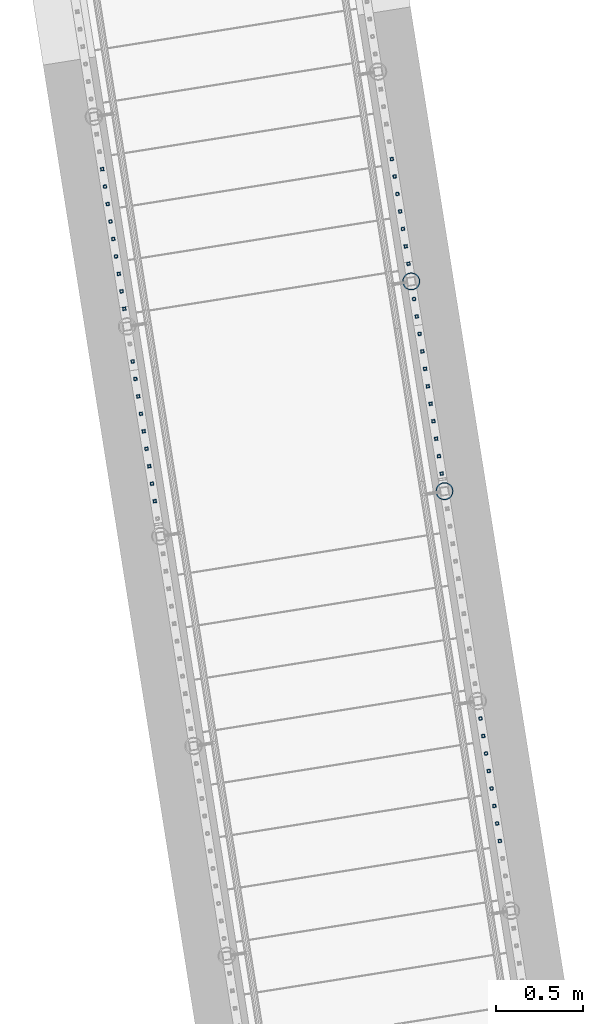
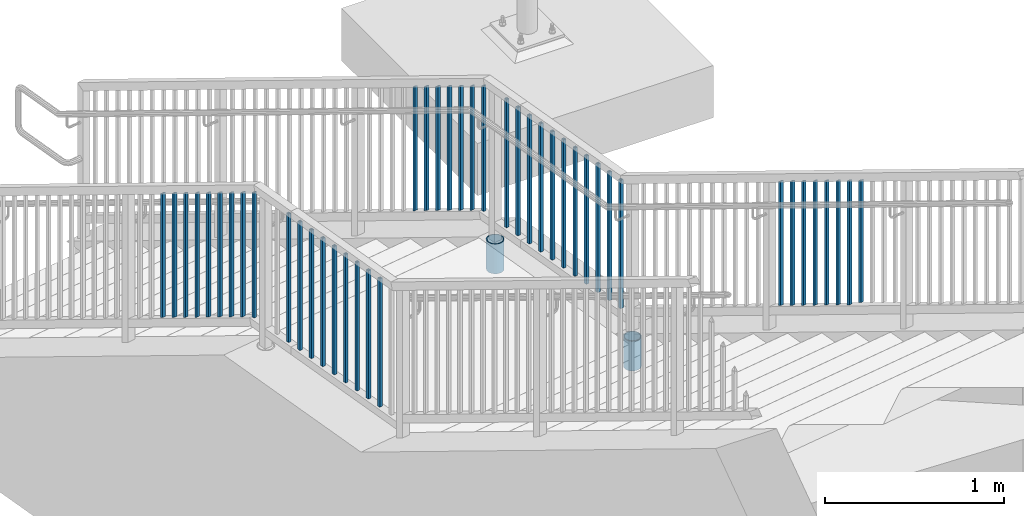
# One storey, part 226 of 975: 46 columns.
"""IFC2X3 building model written with IfcOpenShell, lengths in millimetres."""

from ifc_helpers import new_model, si_unit, frame, origin_with_axes, place, context, subcontext, project, spatial, faceted_brep, material, type_object, element, save


model = new_model("IFC2X3")

# Units and contexts
model_context = context("Model", 3, precision=1e-05, world=origin_with_axes())
body_context = subcontext(model_context, "Body", "Model", "MODEL_VIEW")
ifc_project = project(units=[si_unit("LENGTHUNIT", "METRE", prefix="MILLI"), si_unit("AREAUNIT", "SQUARE_METRE"), si_unit("VOLUMEUNIT", "CUBIC_METRE"), si_unit("MASSUNIT", "GRAM", prefix="KILO"), si_unit("TIMEUNIT", "SECOND"), si_unit("PLANEANGLEUNIT", "RADIAN"), si_unit("SOLIDANGLEUNIT", "STERADIAN"), si_unit("THERMODYNAMICTEMPERATUREUNIT", "DEGREE_CELSIUS"), si_unit("LUMINOUSINTENSITYUNIT", "LUMEN")], contexts=[model_context])

# Site, building, storey
site_placement = place(None, origin_with_axes())
site = spatial("IfcSite", under=ifc_project, at=site_placement, CompositionType="ELEMENT")
building_placement = place(site_placement, origin_with_axes())
building = spatial("IfcBuilding", under=site, at=building_placement, Name="Undefined", CompositionType="ELEMENT")
storey_placement = place(building_placement, origin_with_axes())
storey = spatial("IfcBuildingStorey", under=building, at=storey_placement, Name="Undefined", CompositionType="ELEMENT", Elevation=0.0)

# Columns
ifc_material_1 = material()
column_type_1 = type_object("IfcColumnType", Name="HSS3/4X3/4X.120_TUBES", PredefinedType="NOTDEFINED")
column_1_placement = place(storey_placement, frame((-174.319591391173, 22259.748514681, 3357.53490606116), z_axis=(-0.987688340611262, -0.156434464938429, 0.0), x_axis=(0.0, 0.0, 1.0)))
element("IfcColumn", 1, at=column_1_placement, inside=storey, type_object=column_type_1, material=ifc_material_1, Name="PICKET", ObjectType="HSS3/4X3/4X.120_TUBES", context=body_context, shape_type="Brep", body=[
    faceted_brep([(-3.50571911954194, 6.34999999999491, -6.34999999999809), (3.50573940444565, -6.34999999999491, -6.34999999999991), (838.195107257512, -6.34999999999491, -6.35000000000082), (831.183648729623, 6.34999999999491, -6.34999999999945), (3.50571915819046, -6.34999999998763, 6.34999999999786), (838.195107270213, -6.34999999999127, 6.34999999999809), (-3.50573936579713, 6.34999999999854, 6.34999999999968), (831.183648742323, 6.35000000000218, 6.34999999999945), (-5.25857868897492, 9.5249999999869, -9.52499999999668), (-5.25860905835771, 9.52500000000146, 9.52499999999964), (829.430784113527, 9.52499999999782, 9.52499999999964), (829.430784094476, 9.52499999999054, -9.52499999999827), (5.25857872762344, -9.52499999998327, 9.52499999999645), (839.947971905361, -9.5249999999869, 9.52499999999736), (5.25860909700623, -9.52499999999418, -9.52499999999986), (839.947971886309, -9.52499999999782, -9.525000000001)], [[[0, 1, 2, 3]], [[1, 4, 5, 2]], [[4, 6, 7, 5]], [[6, 0, 3, 7]], [[8, 9, 10, 11]], [[9, 12, 13, 10]], [[12, 14, 15, 13]], [[14, 8, 11, 15]], [[13, 15, 11, 10], [5, 7, 3, 2]], [[14, 12, 9, 8], [6, 4, 1, 0]]]),
])
for number, where, z_axis, x_axis, name in (
    (2, (-190.222182018063, 22360.1535194662, 3301.41200880053), (-0.987688340611262, -0.156434464938429, 0.0), (0.0, 0.0, 1.0), "PICKET"),
    (3, (-206.124772644793, 22460.5585242503, 3245.28911153992), (-0.987688340611262, -0.156434464938429, 0.0), (0.0, 0.0, 1.0), "PICKET"),
    (4, (-222.027363271527, 22560.9635290345, 3189.1662142793), (-0.987688340611262, -0.156434464938429, 0.0), (0.0, 0.0, 1.0), "PICKET"),
    (5, (-237.929953898256, 22661.3685338186, 3133.04331701868), (-0.987688340611262, -0.156434464938429, 0.0), (0.0, 0.0, 1.0), "PICKET"),
    (6, (-253.832544524988, 22761.7735386028, 3076.92041975807), (-0.987688340611262, -0.156434464938429, 0.0), (0.0, 0.0, 1.0), "PICKET"),
    (7, (-269.73513515172, 22862.1785433869, 3020.79752249744), (-0.987688340611262, -0.156434464938429, 0.0), (0.0, 0.0, 1.0), "PICKET"),
    (8, (-285.637725778453, 22962.5835481711, 2964.67462523683), (-0.987688340611262, -0.156434464938429, 0.0), (0.0, 0.0, 1.0), "PICKET"),
):
    element("IfcColumn", number, at=place(storey_placement, frame(where, z_axis=z_axis, x_axis=x_axis)), inside=storey, type_object=column_type_1, material=ifc_material_1, Name=name, ObjectType="HSS3/4X3/4X.120_TUBES", context=body_context, shape_type="Brep", body=[
        faceted_brep([(-17.9916664943412, 6.34999999999491, -6.34999999999945), (-10.9802079664514, -6.34999999999127, -6.35000000000173), (838.195107257512, -6.34999999999491, -6.35000000000082), (831.183648729623, 6.34999999999491, -6.34999999999945), (-10.9802079664505, -6.34999999998763, 6.34999999999764), (838.195107270213, -6.34999999999127, 6.34999999999809), (-17.9916664943403, 6.35000000000218, 6.34999999999945), (831.183648742323, 6.35000000000218, 6.34999999999945), (-19.7445311263136, 9.52499999999054, -9.52499999999918), (-19.7445311263118, 9.52500000000146, 9.52499999999918), (829.430784113527, 9.52499999999782, 9.52499999999964), (829.430784094476, 9.52499999999054, -9.52499999999827), (-9.22734333447806, -9.52499999998327, 9.52499999999691), (839.947971905361, -9.5249999999869, 9.52499999999736), (-9.22734333447897, -9.52499999999418, -9.525000000001), (839.947971886309, -9.52499999999782, -9.525000000001)], [[[0, 1, 2, 3]], [[1, 4, 5, 2]], [[4, 6, 7, 5]], [[6, 0, 3, 7]], [[8, 9, 10, 11]], [[9, 12, 13, 10]], [[12, 14, 15, 13]], [[14, 8, 11, 15]], [[13, 15, 11, 10], [5, 7, 3, 2]], [[14, 12, 9, 8], [6, 4, 1, 0]]]),
    ])
for number, where, z_axis, x_axis, name in (
    (9, (-666.980695255974, 25370.2873334289, 2158.99369648662), (-0.987688340611262, -0.156434464938429, 0.0), (0.0, 0.0, 1.0), "PICKET"),
    (10, (-651.108765229682, 25270.0759091957, 2158.99433328347), (-0.987688340611262, -0.156434464938429, 0.0), (0.0, 0.0, 1.0), "PICKET"),
    (11, (-635.236835203391, 25169.8644849625, 2158.99497008033), (-0.987688340611262, -0.156434464938429, 0.0), (0.0, 0.0, 1.0), "PICKET"),
    (12, (-619.364905177102, 25069.6530607292, 2158.99560687718), (-0.987688340611262, -0.156434464938429, 0.0), (0.0, 0.0, 1.0), "PICKET"),
    (13, (-603.49297515081, 24969.441636496, 2158.99624367404), (-0.987688340611262, -0.156434464938429, 0.0), (0.0, 0.0, 1.0), "PICKET"),
    (14, (-587.621045124519, 24869.2302122628, 2158.99688047089), (-0.987688340611262, -0.156434464938429, 0.0), (0.0, 0.0, 1.0), "PICKET"),
    (15, (-571.749115098228, 24769.0187880295, 2158.99751726774), (-0.987688340611262, -0.156434464938429, 0.0), (0.0, 0.0, 1.0), "PICKET"),
    (16, (-555.877185071937, 24668.8073637963, 2158.9981540646), (-0.987688340611262, -0.156434464938429, 0.0), (0.0, 0.0, 1.0), "PICKET"),
    (17, (-540.005255045646, 24568.5959395631, 2158.99879086145), (-0.987688340611262, -0.156434464938429, 0.0), (0.0, 0.0, 1.0), "PICKET"),
    (18, (-524.133325019354, 24468.3845153298, 2158.99942765831), (-0.987688340611262, -0.156434464938429, 0.0), (0.0, 0.0, 1.0), "PICKET"),
    (19, (-508.261394993011, 24368.1730910962, 2159.00006445516), (-0.987688340611262, -0.156434464938429, 0.0), (0.0, 0.0, 1.0), "PICKET"),
):
    element("IfcColumn", number, at=place(storey_placement, frame(where, z_axis=z_axis, x_axis=x_axis)), inside=storey, type_object=column_type_1, material=ifc_material_1, Name=name, ObjectType="HSS3/4X3/4X.120_TUBES", context=body_context, shape_type="Brep", body=[
        faceted_brep([(0.0, 6.34999999998763, -6.34999999998763), (0.0, -6.35000000000582, -6.34999999998763), (876.3, -6.35000000000218, -6.3500000000131), (876.3, 6.34999999999854, -6.35000000000946), (0.0, -6.34999999998763, 6.34999999998763), (876.3, -6.34999999999854, 6.34999999999127), (0.0, 6.35000000000946, 6.34999999998763), (876.3, 6.35000000000582, 6.34999999999491), (0.0, 9.52499999997963, -9.52499999997963), (0.0, 9.52500000000873, 9.5249999999869), (876.3, 9.52500000000146, 9.52499999999418), (876.3, 9.52499999999782, -9.52500000001237), (0.0, -9.52499999997963, 9.52499999998327), (876.3, -9.52499999999782, 9.52499999999054), (0.0, -9.52500000000873, -9.5249999999869), (876.3, -9.52500000000146, -9.52500000001237)], [[[0, 1, 2, 3]], [[1, 4, 5, 2]], [[4, 6, 7, 5]], [[6, 0, 3, 7]], [[8, 9, 10, 11]], [[9, 12, 13, 10]], [[12, 14, 15, 13]], [[14, 8, 11, 15]], [[13, 15, 11, 10], [5, 7, 3, 2]], [[14, 12, 9, 8], [6, 4, 1, 0]]]),
    ])
for number, where, z_axis, x_axis, name in (
    (20, (-794.217916768308, 26173.6315323476, 1828.42482356432), (-0.987688340611262, -0.156434464938429, 0.0), (0.0, 0.0, 1.0), "PICKET"),
    (21, (-778.345986412301, 26073.4201081623, 1884.43951601803), (-0.987688340611262, -0.156434464938429, 0.0), (0.0, 0.0, 1.0), "PICKET"),
    (22, (-762.474056056291, 25973.2086839769, 1940.45420847175), (-0.987688340611262, -0.156434464938429, 0.0), (0.0, 0.0, 1.0), "PICKET"),
    (23, (-746.602125700283, 25872.9972597915, 1996.46890092546), (-0.987688340611262, -0.156434464938429, 0.0), (0.0, 0.0, 1.0), "PICKET"),
    (24, (-730.730195344275, 25772.7858356061, 2052.48359337918), (-0.987688340611262, -0.156434464938429, 0.0), (0.0, 0.0, 1.0), "PICKET"),
    (25, (-714.858264988266, 25672.5744114208, 2108.49828583289), (-0.987688340611262, -0.156434464938429, 0.0), (0.0, 0.0, 1.0), "PICKET"),
):
    element("IfcColumn", number, at=place(storey_placement, frame(where, z_axis=z_axis, x_axis=x_axis)), inside=storey, type_object=column_type_1, material=ifc_material_1, Name=name, ObjectType="HSS3/4X3/4X.120_TUBES", context=body_context, shape_type="Brep", body=[
        faceted_brep([(-3.50571911954194, 6.34999999999491, -6.34999999999809), (3.50573940444565, -6.34999999999491, -6.34999999999991), (852.681084613786, -6.34999999999491, -6.34999999999991), (845.669626084644, 6.34999999999491, -6.34999999999809), (3.50578071834889, -6.34999999999127, 6.34999999999854), (852.681084601087, -6.34999999998763, 6.34999999999786), (-3.50567908170683, 6.34999999999854, 6.35000000000082), (845.669626071945, 6.34999999999854, 6.34999999999968), (-5.25857868897492, 9.5249999999869, -9.52499999999668), (-5.25854403172048, 9.52499999999782, 9.52500000000055), (843.916761436485, 9.52500000000146, 9.52499999999964), (843.916761455533, 9.5249999999869, -9.52499999999668), (5.25864566836299, -9.5249999999869, 9.52499999999827), (854.433949230198, -9.52499999998327, 9.52499999999645), (5.25860909700623, -9.52499999999418, -9.52499999999986), (854.433949249247, -9.52499999999418, -9.52499999999986)], [[[0, 1, 2, 3]], [[1, 4, 5, 2]], [[4, 6, 7, 5]], [[6, 0, 3, 7]], [[8, 9, 10, 11]], [[9, 12, 13, 10]], [[12, 14, 15, 13]], [[14, 8, 11, 15]], [[13, 15, 11, 10], [5, 7, 3, 2]], [[14, 12, 9, 8], [6, 4, 1, 0]]]),
    ])
column_2_placement = place(storey_placement, frame((-698.986334632485, 25572.3629872368, 2158.99994282035), z_axis=(-0.987688340611262, -0.156434464938429, 0.0), x_axis=(0.0, 0.0, 1.0)))
element("IfcColumn", 26, at=column_2_placement, inside=storey, type_object=column_type_1, material=ifc_material_1, Name="PICKET", ObjectType="HSS3/4X3/4X.120_TUBES", context=body_context, shape_type="Brep", body=[
    faceted_brep([(0.0, 6.34999999998763, -6.34999999998763), (0.0, -6.35000000000582, -6.34999999998763), (858.194079346926, -6.34999999999854, -6.35000000000036), (851.182620819036, 6.34999999999127, -6.34999999999809), (0.0, -6.34999999998763, 6.34999999998763), (858.194079346927, -6.34999999999127, 6.349999999999), (0.0, 6.35000000000946, 6.34999999998763), (851.182620819038, 6.34999999999491, 6.35000000000127), (0.0, 9.52499999997963, -9.52499999997963), (0.0, 9.52500000000873, 9.5249999999869), (849.429756187065, 9.52499999999782, 9.525000000001), (849.429756187064, 9.52499999998327, -9.52499999999736), (0.0, -9.52499999997963, 9.52499999998327), (859.9469439789, -9.5249999999869, 9.52499999999827), (0.0, -9.52500000000873, -9.5249999999869), (859.946943978898, -9.52500000000146, -9.52500000000009)], [[[0, 1, 2, 3]], [[1, 4, 5, 2]], [[4, 6, 7, 5]], [[6, 0, 3, 7]], [[8, 9, 10, 11]], [[9, 12, 13, 10]], [[12, 14, 15, 13]], [[14, 8, 11, 15]], [[13, 15, 11, 10], [5, 7, 3, 2]], [[14, 12, 9, 8], [6, 4, 1, 0]]]),
])
for number, where, z_axis, x_axis, name in (
    (27, (-2456.82941108758, 26115.7503233086, 1716.3954386569), (-0.987688340611262, -0.156434464938429, 0.0), (0.0, 0.0, 1.0), "PICKET"),
    (28, (-2440.95748073175, 26015.5388991234, 1772.41013111062), (-0.987688340611262, -0.156434464938429, 0.0), (0.0, 0.0, 1.0), "PICKET"),
):
    element("IfcColumn", number, at=place(storey_placement, frame(where, z_axis=z_axis, x_axis=x_axis)), inside=storey, type_object=column_type_1, material=ifc_material_1, Name=name, ObjectType="HSS3/4X3/4X.120_TUBES", context=body_context, shape_type="Brep", body=[
        faceted_brep([(-3.50571911954194, 6.34999999999491, -6.34999999999809), (3.50573940444565, -6.34999999999491, -6.34999999999991), (852.681084613786, -6.34999999999491, -6.34999999999991), (845.669626084644, 6.34999999999491, -6.34999999999809), (3.50571915819046, -6.34999999998763, 6.34999999999786), (852.681084601087, -6.34999999998763, 6.34999999999786), (-3.50573936579713, 6.34999999999854, 6.34999999999968), (845.669626071945, 6.34999999999854, 6.34999999999968), (-5.25857868897492, 9.5249999999869, -9.52499999999668), (-5.25860905835771, 9.52500000000146, 9.52499999999964), (843.916761436485, 9.52500000000146, 9.52499999999964), (843.916761455533, 9.5249999999869, -9.52499999999668), (5.25857872762344, -9.52499999998327, 9.52499999999645), (854.433949230198, -9.52499999998327, 9.52499999999645), (5.25860909700623, -9.52499999999418, -9.52499999999986), (854.433949249247, -9.52499999999418, -9.52499999999986)], [[[0, 1, 2, 3]], [[1, 4, 5, 2]], [[4, 6, 7, 5]], [[6, 0, 3, 7]], [[8, 9, 10, 11]], [[9, 12, 13, 10]], [[12, 14, 15, 13]], [[14, 8, 11, 15]], [[13, 15, 11, 10], [5, 7, 3, 2]], [[14, 12, 9, 8], [6, 4, 1, 0]]]),
    ])
for number, where, z_axis, x_axis, name in (
    (29, (-2425.08555037593, 25915.3274749383, 1828.42482356432), (-0.987688340611262, -0.156434464938429, 0.0), (0.0, 0.0, 1.0), "PICKET"),
    (30, (-2409.2136200201, 25815.1160507532, 1884.43951601803), (-0.987688340611262, -0.156434464938429, 0.0), (0.0, 0.0, 1.0), "PICKET"),
    (31, (-2393.34168966428, 25714.904626568, 1940.45420847175), (-0.987688340611262, -0.156434464938429, 0.0), (0.0, 0.0, 1.0), "PICKET"),
    (32, (-2377.46975930845, 25614.6932023829, 1996.46890092546), (-0.987688340611262, -0.156434464938429, 0.0), (0.0, 0.0, 1.0), "PICKET"),
    (33, (-2361.59782895263, 25514.4817781978, 2052.48359337918), (-0.987688340611262, -0.156434464938429, 0.0), (0.0, 0.0, 1.0), "PICKET"),
    (34, (-2345.7258985968, 25414.2703540126, 2108.49828583289), (-0.987688340611262, -0.156434464938429, 0.0), (0.0, 0.0, 1.0), "PICKET"),
):
    element("IfcColumn", number, at=place(storey_placement, frame(where, z_axis=z_axis, x_axis=x_axis)), inside=storey, type_object=column_type_1, material=ifc_material_1, Name=name, ObjectType="HSS3/4X3/4X.120_TUBES", context=body_context, shape_type="Brep", body=[
        faceted_brep([(-3.50571911954194, 6.34999999999491, -6.34999999999809), (3.50573940444565, -6.34999999999491, -6.34999999999991), (852.681084613786, -6.34999999999491, -6.34999999999991), (845.669626084644, 6.34999999999491, -6.34999999999809), (3.50578071834889, -6.34999999999127, 6.34999999999854), (852.681084601087, -6.34999999998763, 6.34999999999786), (-3.50567908170683, 6.34999999999854, 6.35000000000082), (845.669626071945, 6.34999999999854, 6.34999999999968), (-5.25857868897492, 9.5249999999869, -9.52499999999668), (-5.25854403172048, 9.52499999999782, 9.52500000000055), (843.916761436485, 9.52500000000146, 9.52499999999964), (843.916761455533, 9.5249999999869, -9.52499999999668), (5.25864566836299, -9.5249999999869, 9.52499999999827), (854.433949230198, -9.52499999998327, 9.52499999999645), (5.25860909700623, -9.52499999999418, -9.52499999999986), (854.433949249247, -9.52499999999418, -9.52499999999986)], [[[0, 1, 2, 3]], [[1, 4, 5, 2]], [[4, 6, 7, 5]], [[6, 0, 3, 7]], [[8, 9, 10, 11]], [[9, 12, 13, 10]], [[12, 14, 15, 13]], [[14, 8, 11, 15]], [[13, 15, 11, 10], [5, 7, 3, 2]], [[14, 12, 9, 8], [6, 4, 1, 0]]]),
    ])
column_3_placement = place(storey_placement, frame((-2329.85396824121, 25314.0589298289, 2158.99994282035), z_axis=(-0.987688340611262, -0.156434464938429, 0.0), x_axis=(0.0, 0.0, 1.0)))
element("IfcColumn", 35, at=column_3_placement, inside=storey, type_object=column_type_1, material=ifc_material_1, Name="PICKET", ObjectType="HSS3/4X3/4X.120_TUBES", context=body_context, shape_type="Brep", body=[
    faceted_brep([(0.0, 6.34999999998763, -6.34999999998763), (0.0, -6.35000000000582, -6.34999999998763), (858.194079346926, -6.34999999999854, -6.35000000000036), (851.182620819036, 6.34999999999127, -6.34999999999809), (0.0, -6.34999999998763, 6.34999999998763), (858.194079346927, -6.34999999999127, 6.349999999999), (0.0, 6.35000000000946, 6.34999999998763), (851.182620819038, 6.34999999999491, 6.35000000000127), (0.0, 9.52499999997963, -9.52499999997963), (0.0, 9.52500000000873, 9.5249999999869), (849.429756187065, 9.52499999999782, 9.525000000001), (849.429756187064, 9.52499999998327, -9.52499999999736), (0.0, -9.52499999997963, 9.52499999998327), (859.9469439789, -9.5249999999869, 9.52499999999827), (0.0, -9.52500000000873, -9.5249999999869), (859.946943978898, -9.52500000000146, -9.52500000000009)], [[[0, 1, 2, 3]], [[1, 4, 5, 2]], [[4, 6, 7, 5]], [[6, 0, 3, 7]], [[8, 9, 10, 11]], [[9, 12, 13, 10]], [[12, 14, 15, 13]], [[14, 8, 11, 15]], [[13, 15, 11, 10], [5, 7, 3, 2]], [[14, 12, 9, 8], [6, 4, 1, 0]]]),
])
for number, where, z_axis, x_axis, name in (
    (36, (-2281.97639883896, 25011.7718517885, 2158.99433328347), (-0.987688340611262, -0.156434464938429, 0.0), (0.0, 0.0, 1.0), "PICKET"),
    (37, (-2266.10446881285, 24911.5604275555, 2158.99497008033), (-0.987688340611262, -0.156434464938429, 0.0), (0.0, 0.0, 1.0), "PICKET"),
    (38, (-2250.23253878674, 24811.3490033225, 2158.99560687718), (-0.987688340611262, -0.156434464938429, 0.0), (0.0, 0.0, 1.0), "PICKET"),
    (39, (-2234.36060876063, 24711.1375790895, 2158.99624367404), (-0.987688340611262, -0.156434464938429, 0.0), (0.0, 0.0, 1.0), "PICKET"),
    (40, (-2218.48867873453, 24610.9261548565, 2158.99688047089), (-0.987688340611262, -0.156434464938429, 0.0), (0.0, 0.0, 1.0), "PICKET"),
    (41, (-2202.61674870842, 24510.7147306235, 2158.99751726774), (-0.987688340611262, -0.156434464938429, 0.0), (0.0, 0.0, 1.0), "PICKET"),
    (42, (-2186.74481868231, 24410.5033063905, 2158.9981540646), (-0.987688340611262, -0.156434464938429, 0.0), (0.0, 0.0, 1.0), "PICKET"),
    (43, (-2170.8728886562, 24310.2918821575, 2158.99879086145), (-0.987688340611262, -0.156434464938429, 0.0), (0.0, 0.0, 1.0), "PICKET"),
    (44, (-2155.00095863009, 24210.0804579245, 2158.99942765831), (-0.987688340611262, -0.156434464938429, 0.0), (0.0, 0.0, 1.0), "PICKET"),
):
    element("IfcColumn", number, at=place(storey_placement, frame(where, z_axis=z_axis, x_axis=x_axis)), inside=storey, type_object=column_type_1, material=ifc_material_1, Name=name, ObjectType="HSS3/4X3/4X.120_TUBES", context=body_context, shape_type="Brep", body=[
        faceted_brep([(0.0, 6.34999999998763, -6.34999999998763), (0.0, -6.35000000000582, -6.34999999998763), (876.3, -6.35000000000218, -6.3500000000131), (876.3, 6.34999999999854, -6.35000000000946), (0.0, -6.34999999998763, 6.34999999998763), (876.3, -6.34999999999854, 6.34999999999127), (0.0, 6.35000000000946, 6.34999999998763), (876.3, 6.35000000000582, 6.34999999999491), (0.0, 9.52499999997963, -9.52499999997963), (0.0, 9.52500000000873, 9.5249999999869), (876.3, 9.52500000000146, 9.52499999999418), (876.3, 9.52499999999782, -9.52500000001237), (0.0, -9.52499999997963, 9.52499999998327), (876.3, -9.52499999999782, 9.52499999999054), (0.0, -9.52500000000873, -9.5249999999869), (876.3, -9.52500000000146, -9.52500000001237)], [[[0, 1, 2, 3]], [[1, 4, 5, 2]], [[4, 6, 7, 5]], [[6, 0, 3, 7]], [[8, 9, 10, 11]], [[9, 12, 13, 10]], [[12, 14, 15, 13]], [[14, 8, 11, 15]], [[13, 15, 11, 10], [5, 7, 3, 2]], [[14, 12, 9, 8], [6, 4, 1, 0]]]),
    ])
ifc_material_2 = material(Name="STEEL/A53")
column_type_2 = type_object("IfcColumnType", Name="PIPE3-1/2STD", PredefinedType="NOTDEFINED")
column_4_placement = place(storey_placement, frame((-682.990817348667, 25471.3674930778, 1816.09994848937), z_axis=(0.587785252279345, 0.809016994384486, -8.09014238711826e-10), x_axis=(0.0, 0.0, 1.0)))
element("IfcColumn", 45, at=column_4_placement, inside=storey, type_object=column_type_2, material=ifc_material_2, ObjectType="PIPE3-1/2STD", context=body_context, shape_type="Brep", body=[
    faceted_brep([(0.0, -45.0595999999932, 1.45519152283669e-11), (0.0, -42.8542262016344, 13.924182159768), (203.199999999991, -42.8542262017145, 13.9241821598171), (203.19999999999, -45.0596000000478, 5.82076609134674e-11), (0.0, -36.45398215971, 26.4853683542424), (203.199999999993, -36.45398215981, 26.4853683542988), (0.0, -26.4853683541623, 36.45398215979), (203.199999999995, -26.4853683542788, 36.4539821598537), (0.0, -13.9241821596988, 42.8542262017108), (203.199999999998, -13.9241821598262, 42.8542262017836), (0.0, 3.63797880709171e-11, 45.0596000000514), (203.2, -9.27684595808387e-11, 45.0596000001387), (0.0, 13.9241821597716, 42.8542262017036), (203.200000000003, 13.9241821596443, 42.8542262017927), (0.0, 26.4853683542242, 36.4539821597718), (203.200000000006, 26.4853683541096, 36.4539821598701), (0.0, 36.4539821597537, 26.4853683542206), (203.200000000008, 36.4539821596554, 26.4853683543224), (0.0, 42.8542262016563, 13.9241821597425), (203.200000000009, 42.8542262015817, 13.9241821598443), (0.0, 45.0595999999932, -1.09139364212751e-11), (203.200000000009, 45.0595999999423, 8.9130480773747e-11), (0.0, 42.8542262016344, -13.9241821597643), (203.200000000008, 42.854226201609, -13.9241821596697), (0.0, 36.45398215971, -26.4853683542387), (203.200000000007, 36.4539821597045, -26.4853683541514), (0.0, 26.4853683541623, -36.4539821597864), (203.200000000004, 26.4853683541733, -36.4539821597064), (0.0, 13.9241821596988, -42.8542262017072), (203.200000000002, 13.9241821597225, -42.8542262016381), (0.0, -3.63797880709171e-11, -45.0596000000478), (203.199999999999, -9.09494701772928e-12, -45.0595999999914), (0.0, -13.9241821597716, -42.8542262016963), (203.199999999996, -13.9241821597479, -42.8542262016472), (0.0, -26.4853683542242, -36.4539821597682), (203.199999999993, -26.4853683542133, -36.4539821597227), (0.0, -36.4539821597537, -26.4853683542169), (203.199999999992, -36.4539821597609, -26.4853683541751), (0.0, -42.8542262016563, -13.9241821597352), (203.199999999991, -42.8542262016872, -13.924182159697), (0.0, -50.799999999992, 1.81898940354586e-11), (0.0, -48.3136710278013, -15.6980633142484), (203.199999999989, -48.313671027825, -15.6980633142139), (203.199999999989, -50.8000000000466, 5.63886715099216e-11), (0.0, -41.0980633142644, -29.8594908164741), (203.19999999999, -41.0980633142663, -29.8594908164414), (0.0, -29.859490816485, -41.0980633142826), (203.199999999993, -29.8594908164687, -41.0980633142426), (0.0, -15.6980633142848, -48.313671027845), (203.199999999995, -15.6980633142539, -48.313671027794), (0.0, -4.36557456851006e-11, -50.8000000000575), (203.199999999998, -7.27595761418343e-12, -50.7999999999993), (0.0, 15.6980633142011, -48.3136710278523), (203.200000000002, 15.6980633142375, -48.3136710277831), (0.0, 29.8594908164159, -41.0980633143045), (203.200000000005, 29.8594908164378, -41.0980633142226), (0.0, 41.0980633142135, -29.8594908165032), (203.200000000008, 41.0980633142171, -29.8594908164141), (0.0, 48.3136710277722, -15.6980633142775), (203.200000000009, 48.3136710277504, -15.6980633141811), (0.0, 50.799999999992, -1.45519152283669e-11), (203.20000000001, 50.7999999999411, 9.09494701772928e-11), (0.0, 48.313671027794, 15.6980633142521), (203.20000000001, 48.3136710277213, 15.6980633143594), (0.0, 41.0980633142644, 29.8594908164814), (203.200000000008, 41.0980633141626, 29.8594908165887), (0.0, 29.859490816485, 41.0980633142863), (203.200000000007, 29.8594908163632, 41.0980633143899), (0.0, 15.6980633142848, 48.3136710278486), (203.200000000004, 15.6980633141484, 48.3136710279414), (0.0, 4.00177668780088e-11, 50.8000000000611), (203.200000000001, -9.82254277914762e-11, 50.8000000001466), (0.0, -15.6980633142011, 48.3136710278559), (203.199999999997, -15.698063314343, 48.3136710279305), (0.0, -29.8594908164159, 41.0980633143081), (203.199999999994, -29.8594908165433, 41.0980633143681), (0.0, -41.0980633142171, 29.8594908165069), (203.199999999992, -41.0980633143226, 29.8594908165596), (0.0, -48.3136710277722, 15.6980633142812), (203.19999999999, -48.3136710278559, 15.6980633143285)], [[[0, 1, 2, 3]], [[1, 4, 5, 2]], [[4, 6, 7, 5]], [[6, 8, 9, 7]], [[8, 10, 11, 9]], [[10, 12, 13, 11]], [[12, 14, 15, 13]], [[14, 16, 17, 15]], [[16, 18, 19, 17]], [[18, 20, 21, 19]], [[20, 22, 23, 21]], [[22, 24, 25, 23]], [[24, 26, 27, 25]], [[26, 28, 29, 27]], [[28, 30, 31, 29]], [[30, 32, 33, 31]], [[32, 34, 35, 33]], [[34, 36, 37, 35]], [[36, 38, 39, 37]], [[38, 0, 3, 39]], [[40, 41, 42, 43]], [[41, 44, 45, 42]], [[44, 46, 47, 45]], [[46, 48, 49, 47]], [[48, 50, 51, 49]], [[50, 52, 53, 51]], [[52, 54, 55, 53]], [[54, 56, 57, 55]], [[56, 58, 59, 57]], [[58, 60, 61, 59]], [[60, 62, 63, 61]], [[62, 64, 65, 63]], [[64, 66, 67, 65]], [[66, 68, 69, 67]], [[68, 70, 71, 69]], [[70, 72, 73, 71]], [[72, 74, 75, 73]], [[74, 76, 77, 75]], [[76, 78, 79, 77]], [[78, 40, 43, 79]], [[45, 47, 49, 51, 53, 55, 57, 59, 61, 63, 65, 67, 69, 71, 73, 75, 77, 79, 43, 42], [5, 7, 9, 11, 13, 15, 17, 19, 21, 23, 25, 27, 29, 31, 33, 35, 37, 39, 3, 2]], [[78, 76, 74, 72, 70, 68, 66, 64, 62, 60, 58, 56, 54, 52, 50, 48, 46, 44, 41, 40], [38, 36, 34, 32, 30, 28, 26, 24, 22, 20, 18, 16, 14, 12, 10, 8, 6, 4, 1, 0]]]),
])
column_5_placement = place(storey_placement, frame((-492.26594889316, 24267.1780651905, 1816.0998842966), z_axis=(0.587785252279345, 0.809016994384486, -8.09014238711826e-10), x_axis=(0.0, 0.0, 1.0)))
element("IfcColumn", 46, at=column_5_placement, inside=storey, type_object=column_type_2, material=ifc_material_2, ObjectType="PIPE3-1/2STD", context=body_context, shape_type="Brep", body=[
    faceted_brep([(0.0, -45.0595999999932, 1.45519152283669e-11), (0.0, -42.8542262016344, 13.924182159768), (203.199999999991, -42.8542262017145, 13.9241821598171), (203.19999999999, -45.0596000000478, 5.82076609134674e-11), (0.0, -36.45398215971, 26.4853683542424), (203.199999999993, -36.45398215981, 26.4853683542988), (0.0, -26.4853683541623, 36.45398215979), (203.199999999995, -26.4853683542788, 36.4539821598537), (0.0, -13.9241821596988, 42.8542262017108), (203.199999999998, -13.9241821598262, 42.8542262017836), (0.0, 3.63797880709171e-11, 45.0596000000514), (203.2, -9.27684595808387e-11, 45.0596000001387), (0.0, 13.9241821597716, 42.8542262017036), (203.200000000003, 13.9241821596443, 42.8542262017927), (0.0, 26.4853683542242, 36.4539821597718), (203.200000000006, 26.4853683541096, 36.4539821598701), (0.0, 36.4539821597537, 26.4853683542206), (203.200000000008, 36.4539821596554, 26.4853683543224), (0.0, 42.8542262016563, 13.9241821597425), (203.200000000009, 42.8542262015817, 13.9241821598443), (0.0, 45.0595999999932, -1.09139364212751e-11), (203.200000000009, 45.0595999999423, 8.9130480773747e-11), (0.0, 42.8542262016344, -13.9241821597643), (203.200000000008, 42.854226201609, -13.9241821596697), (0.0, 36.45398215971, -26.4853683542387), (203.200000000007, 36.4539821597045, -26.4853683541514), (0.0, 26.4853683541623, -36.4539821597864), (203.200000000004, 26.4853683541733, -36.4539821597064), (0.0, 13.9241821596988, -42.8542262017072), (203.200000000002, 13.9241821597225, -42.8542262016381), (0.0, -3.63797880709171e-11, -45.0596000000478), (203.199999999999, -9.09494701772928e-12, -45.0595999999914), (0.0, -13.9241821597716, -42.8542262016963), (203.199999999996, -13.9241821597479, -42.8542262016472), (0.0, -26.4853683542242, -36.4539821597682), (203.199999999993, -26.4853683542133, -36.4539821597227), (0.0, -36.4539821597537, -26.4853683542169), (203.199999999992, -36.4539821597609, -26.4853683541751), (0.0, -42.8542262016563, -13.9241821597352), (203.199999999991, -42.8542262016872, -13.924182159697), (0.0, -50.799999999992, 1.81898940354586e-11), (0.0, -48.3136710278013, -15.6980633142484), (203.199999999989, -48.313671027825, -15.6980633142139), (203.199999999989, -50.8000000000466, 5.63886715099216e-11), (0.0, -41.0980633142644, -29.8594908164741), (203.19999999999, -41.0980633142663, -29.8594908164414), (0.0, -29.859490816485, -41.0980633142826), (203.199999999993, -29.8594908164687, -41.0980633142426), (0.0, -15.6980633142848, -48.313671027845), (203.199999999995, -15.6980633142539, -48.313671027794), (0.0, -4.36557456851006e-11, -50.8000000000575), (203.199999999998, -7.27595761418343e-12, -50.7999999999993), (0.0, 15.6980633142011, -48.3136710278523), (203.200000000002, 15.6980633142375, -48.3136710277831), (0.0, 29.8594908164159, -41.0980633143045), (203.200000000005, 29.8594908164378, -41.0980633142226), (0.0, 41.0980633142135, -29.8594908165032), (203.200000000008, 41.0980633142171, -29.8594908164141), (0.0, 48.3136710277722, -15.6980633142775), (203.200000000009, 48.3136710277504, -15.6980633141811), (0.0, 50.799999999992, -1.45519152283669e-11), (203.20000000001, 50.7999999999411, 9.09494701772928e-11), (0.0, 48.313671027794, 15.6980633142521), (203.20000000001, 48.3136710277213, 15.6980633143594), (0.0, 41.0980633142644, 29.8594908164814), (203.200000000008, 41.0980633141626, 29.8594908165887), (0.0, 29.859490816485, 41.0980633142863), (203.200000000007, 29.8594908163632, 41.0980633143899), (0.0, 15.6980633142848, 48.3136710278486), (203.200000000004, 15.6980633141484, 48.3136710279414), (0.0, 4.00177668780088e-11, 50.8000000000611), (203.200000000001, -9.82254277914762e-11, 50.8000000001466), (0.0, -15.6980633142011, 48.3136710278559), (203.199999999997, -15.698063314343, 48.3136710279305), (0.0, -29.8594908164159, 41.0980633143081), (203.199999999994, -29.8594908165433, 41.0980633143681), (0.0, -41.0980633142171, 29.8594908165069), (203.199999999992, -41.0980633143226, 29.8594908165596), (0.0, -48.3136710277722, 15.6980633142812), (203.19999999999, -48.3136710278559, 15.6980633143285)], [[[0, 1, 2, 3]], [[1, 4, 5, 2]], [[4, 6, 7, 5]], [[6, 8, 9, 7]], [[8, 10, 11, 9]], [[10, 12, 13, 11]], [[12, 14, 15, 13]], [[14, 16, 17, 15]], [[16, 18, 19, 17]], [[18, 20, 21, 19]], [[20, 22, 23, 21]], [[22, 24, 25, 23]], [[24, 26, 27, 25]], [[26, 28, 29, 27]], [[28, 30, 31, 29]], [[30, 32, 33, 31]], [[32, 34, 35, 33]], [[34, 36, 37, 35]], [[36, 38, 39, 37]], [[38, 0, 3, 39]], [[40, 41, 42, 43]], [[41, 44, 45, 42]], [[44, 46, 47, 45]], [[46, 48, 49, 47]], [[48, 50, 51, 49]], [[50, 52, 53, 51]], [[52, 54, 55, 53]], [[54, 56, 57, 55]], [[56, 58, 59, 57]], [[58, 60, 61, 59]], [[60, 62, 63, 61]], [[62, 64, 65, 63]], [[64, 66, 67, 65]], [[66, 68, 69, 67]], [[68, 70, 71, 69]], [[70, 72, 73, 71]], [[72, 74, 75, 73]], [[74, 76, 77, 75]], [[76, 78, 79, 77]], [[78, 40, 43, 79]], [[45, 47, 49, 51, 53, 55, 57, 59, 61, 63, 65, 67, 69, 71, 73, 75, 77, 79, 43, 42], [5, 7, 9, 11, 13, 15, 17, 19, 21, 23, 25, 27, 29, 31, 33, 35, 37, 39, 3, 2]], [[78, 76, 74, 72, 70, 68, 66, 64, 62, 60, 58, 56, 54, 52, 50, 48, 46, 44, 41, 40], [38, 36, 34, 32, 30, 28, 26, 24, 22, 20, 18, 16, 14, 12, 10, 8, 6, 4, 1, 0]]]),
])

save(model, "model.ifc")
